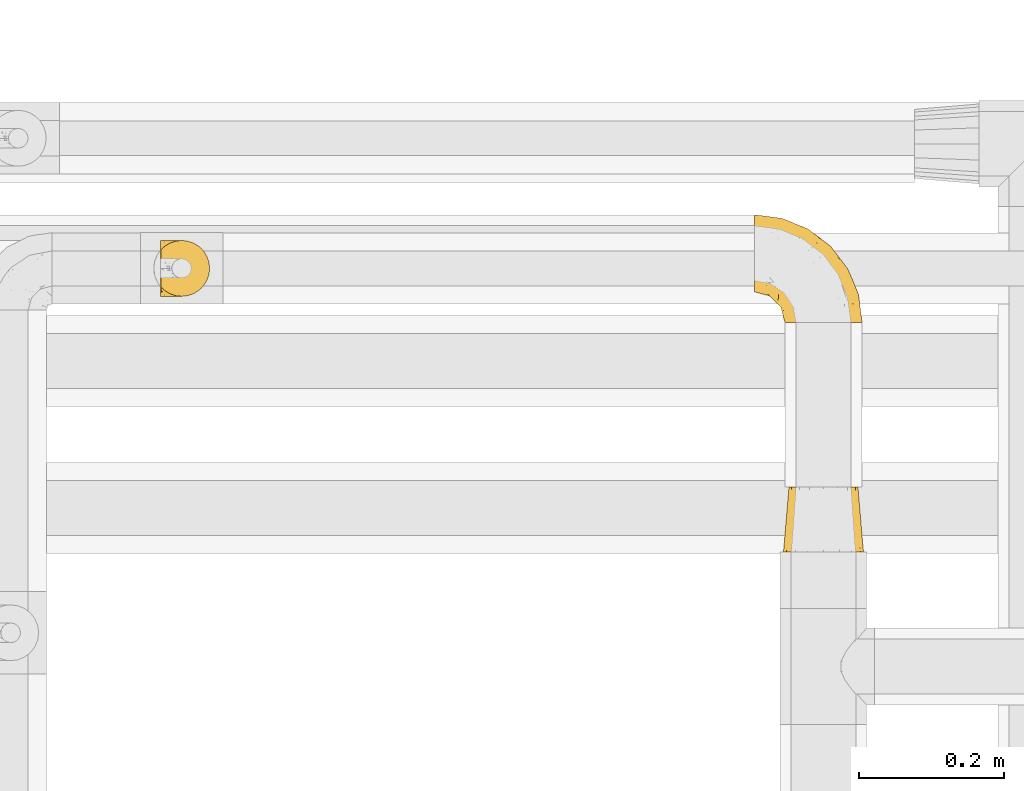
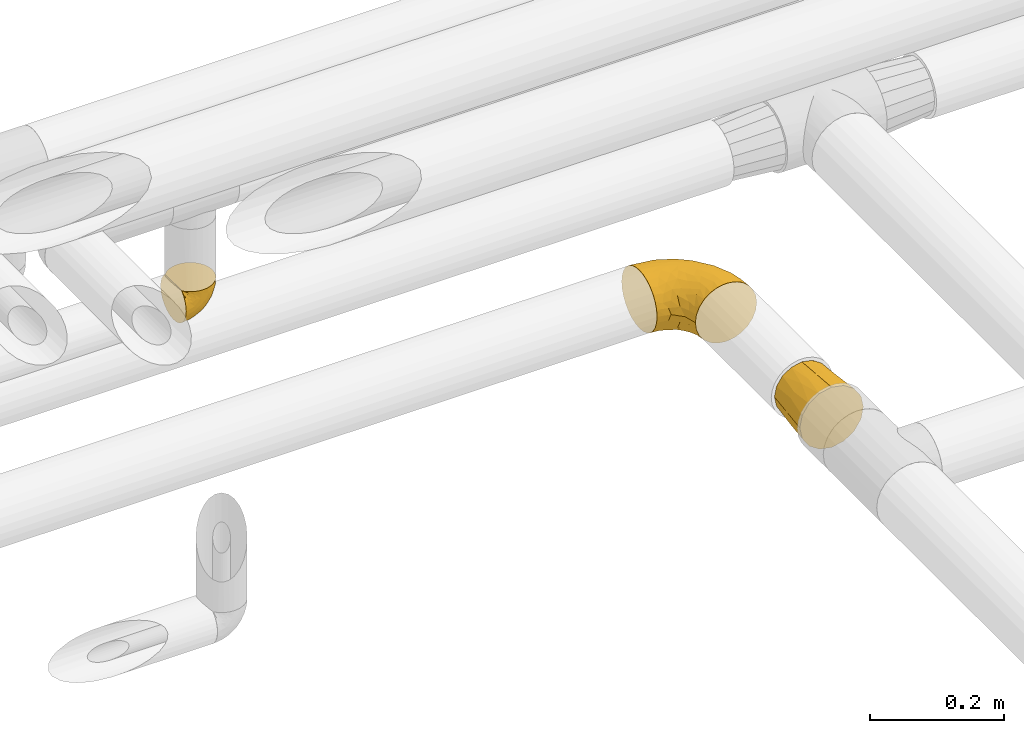
# One storey, part 366 of 827: 3 coverings.
"""IFC2X3 building model written with IfcOpenShell, lengths in millimetres."""

from ifc_helpers import new_model, entity, si_unit, converted_unit, derived_unit, direction, frame, origin, place, context, subcontext, project, spatial, faceted_brep, element, save


model = new_model("IFC2X3")

# Units and contexts
model_context = context("Model", 3, precision=0.01, world=origin(), true_north=direction((6.12303176911189e-17, 1.0)))
body_context = subcontext(model_context, "Body", "Model", "MODEL_VIEW")
ifc_project = project(units=[si_unit("LENGTHUNIT", "METRE", prefix="MILLI"), si_unit("AREAUNIT", "SQUARE_METRE"), si_unit("VOLUMEUNIT", "CUBIC_METRE"), converted_unit("PLANEANGLEUNIT", "DEGREE", entity("IfcRatioMeasure", 0.0174532925199433), si_unit("PLANEANGLEUNIT", "RADIAN"), dimensions=[0, 0, 0, 0, 0, 0, 0]), si_unit("MASSUNIT", "GRAM", prefix="KILO"), derived_unit("MASSDENSITYUNIT", [(si_unit("MASSUNIT", "GRAM", prefix="KILO"), 1), (si_unit("LENGTHUNIT", "METRE"), -3)]), derived_unit("MOMENTOFINERTIAUNIT", [(si_unit("LENGTHUNIT", "METRE"), 4)]), si_unit("TIMEUNIT", "SECOND"), si_unit("FREQUENCYUNIT", "HERTZ"), si_unit("THERMODYNAMICTEMPERATUREUNIT", "DEGREE_CELSIUS"), derived_unit("THERMALTRANSMITTANCEUNIT", [(si_unit("MASSUNIT", "GRAM", prefix="KILO"), 1), (si_unit("THERMODYNAMICTEMPERATUREUNIT", "KELVIN"), -1), (si_unit("TIMEUNIT", "SECOND"), -3)]), derived_unit("VOLUMETRICFLOWRATEUNIT", [(si_unit("LENGTHUNIT", "METRE"), 3), (si_unit("TIMEUNIT", "SECOND"), -1)]), derived_unit("MASSFLOWRATEUNIT", [(si_unit("MASSUNIT", "GRAM", prefix="KILO"), 1), (si_unit("TIMEUNIT", "SECOND"), -1)]), derived_unit("ROTATIONALFREQUENCYUNIT", [(si_unit("TIMEUNIT", "SECOND"), -1)]), si_unit("ELECTRICCURRENTUNIT", "AMPERE"), si_unit("ELECTRICVOLTAGEUNIT", "VOLT"), si_unit("POWERUNIT", "WATT"), si_unit("FORCEUNIT", "NEWTON", prefix="KILO"), si_unit("ILLUMINANCEUNIT", "LUX"), si_unit("LUMINOUSFLUXUNIT", "LUMEN"), si_unit("LUMINOUSINTENSITYUNIT", "CANDELA"), derived_unit("USERDEFINED", [(si_unit("MASSUNIT", "GRAM", prefix="KILO"), -1), (si_unit("LENGTHUNIT", "METRE"), -2), (si_unit("TIMEUNIT", "SECOND"), 3), (si_unit("LUMINOUSFLUXUNIT", "LUMEN"), 1)]), derived_unit("LINEARVELOCITYUNIT", [(si_unit("LENGTHUNIT", "METRE"), 1), (si_unit("TIMEUNIT", "SECOND"), -1)]), si_unit("PRESSUREUNIT", "PASCAL"), derived_unit("USERDEFINED", [(si_unit("LENGTHUNIT", "METRE"), -2), (si_unit("MASSUNIT", "GRAM", prefix="KILO"), 1), (si_unit("TIMEUNIT", "SECOND"), -2)]), derived_unit("LINEARFORCEUNIT", [(si_unit("MASSUNIT", "GRAM", prefix="KILO"), 1), (si_unit("LENGTHUNIT", "METRE"), 1), (si_unit("TIMEUNIT", "SECOND"), -2), (si_unit("LENGTHUNIT", "METRE"), -1)]), derived_unit("PLANARFORCEUNIT", [(si_unit("MASSUNIT", "GRAM", prefix="KILO"), 1), (si_unit("LENGTHUNIT", "METRE"), 1), (si_unit("TIMEUNIT", "SECOND"), -2), (si_unit("LENGTHUNIT", "METRE"), -2)])], contexts=[model_context])

# Site, building, storey
site_placement = place(None, origin())
site = spatial("IfcSite", under=ifc_project, at=site_placement, CompositionType="ELEMENT")
building_placement = place(site_placement, origin())
building = spatial("IfcBuilding", under=site, at=building_placement, CompositionType="ELEMENT")
storey_placement = place(building_placement, frame((0.0, 0.0, 28200.0)))
storey = spatial("IfcBuildingStorey", under=building, at=storey_placement, Name="08", CompositionType="ELEMENT", Elevation=28200.0)

# Coverings
covering_1_placement = place(storey_placement, frame((36834.33, 18896.36, 3159.95)))
element("IfcCovering", 1, at=covering_1_placement, inside=storey, Name=":ADSK_", ObjectType=":ADSK_", PredefinedType="INSULATION", context=body_context, shape_type="Brep", body=[
    faceted_brep([(47.38, 5.41, 69.15), (54.67, 9.99, 69.15), (60.76, 16.08, 69.15), (65.34, 23.37, 69.15), (68.18, 31.49, 69.15), (69.15, 40.05, 69.15), (68.18, 48.61, 69.15), (65.33, 56.73, 69.15), (60.75, 64.02, 69.15), (54.66, 70.11, 69.15), (47.37, 74.69, 69.15), (39.25, 77.53, 69.15), (30.7, 78.5, 69.15), (22.59, 77.63, 69.15), (14.86, 75.08, 69.15), (7.84, 70.97, 69.15), (1.85, 65.47, 69.15), (1.85, 63.27, 69.15), (1.85, 61.53, 69.15), (1.85, 59.57, 69.15), (1.85, 57.6, 69.15), (1.85, 55.63, 69.15), (1.85, 53.67, 69.15), (1.85, 51.7, 69.15), (1.85, 49.73, 69.15), (1.85, 47.54, 69.15), (1.85, 45.34, 69.15), (1.85, 43.15, 69.15), (1.85, 40.96, 69.15), (1.85, 38.76, 69.15), (1.85, 36.57, 69.15), (1.85, 34.37, 69.15), (1.85, 32.18, 69.15), (1.85, 29.98, 69.15), (1.85, 27.79, 69.15), (1.85, 25.6, 69.15), (1.85, 23.4, 69.15), (1.85, 21.21, 69.15), (1.85, 19.01, 69.15), (1.85, 16.82, 69.15), (1.85, 14.62, 69.15), (7.85, 9.12, 69.15), (14.88, 5.0, 69.15), (22.61, 2.46, 69.15), (30.7, 1.6, 69.15), (39.26, 2.56, 69.15), (1.6, 65.47, 68.89), (1.6, 70.97, 62.89), (1.6, 75.09, 55.87), (1.6, 77.63, 48.14), (1.6, 78.5, 40.05), (1.6, 77.19, 30.09), (1.6, 73.34, 20.82), (1.6, 67.23, 12.86), (1.6, 59.27, 6.75), (1.6, 50.0, 2.91), (1.6, 40.05, 1.6), (1.6, 30.09, 2.91), (1.6, 20.82, 6.75), (1.6, 12.86, 12.86), (1.6, 6.75, 20.82), (1.6, 2.91, 30.09), (1.6, 1.6, 40.05), (1.6, 2.46, 48.14), (1.6, 5.0, 55.87), (1.6, 9.12, 62.89), (1.6, 14.62, 68.89), (1.6, 16.82, 68.89), (1.6, 17.8, 68.89), (1.6, 19.39, 68.89), (1.6, 20.98, 68.89), (1.6, 22.57, 68.89), (1.6, 24.16, 68.89), (1.6, 25.75, 68.89), (1.6, 27.33, 68.89), (1.6, 28.92, 68.89), (1.6, 30.51, 68.89), (1.6, 32.1, 68.89), (1.6, 33.69, 68.89), (1.6, 35.28, 68.89), (1.6, 36.87, 68.89), (1.6, 38.46, 68.89), (1.6, 40.05, 68.89), (1.6, 41.63, 68.89), (1.6, 43.22, 68.89), (1.6, 44.81, 68.89), (1.6, 46.4, 68.89), (1.6, 47.99, 68.89), (1.6, 49.58, 68.89), (1.6, 51.17, 68.89), (1.6, 52.76, 68.89), (1.6, 54.72, 68.89), (1.6, 56.69, 68.89), (1.6, 58.88, 68.89), (1.6, 61.08, 68.89), (1.6, 63.27, 68.89), (1.78, 37.77, 68.97), (1.77, 36.07, 68.96), (1.78, 32.96, 68.97), (1.77, 31.36, 68.97), (1.79, 56.52, 68.98), (1.78, 54.96, 68.97), (1.76, 18.75, 68.96), (1.77, 58.07, 68.96), (1.77, 50.37, 68.96), (1.76, 23.36, 68.96), (1.77, 24.95, 68.96), (1.77, 42.43, 68.96), (1.8, 15.97, 69.0), (1.76, 51.96, 68.96), (1.77, 53.47, 68.96), (1.78, 48.63, 68.97), (1.77, 63.93, 68.96), (1.77, 40.93, 68.96), (1.76, 29.72, 68.96), (1.77, 62.4, 68.97), (1.78, 60.92, 68.97), (1.77, 17.31, 68.97), (1.77, 21.74, 68.96), (1.77, 34.56, 68.96), (1.78, 20.18, 68.97), (1.77, 14.62, 68.97), (1.8, 14.62, 69.02), (1.82, 14.62, 69.08), (1.77, 65.47, 68.97), (1.72, 65.47, 68.94), (1.66, 65.47, 68.92), (1.76, 59.5, 68.96), (1.77, 47.1, 68.96), (1.76, 45.61, 68.95), (1.77, 28.18, 68.96), (1.66, 14.62, 68.92), (1.72, 14.62, 68.94), (1.78, 26.61, 68.98), (1.82, 65.47, 69.08), (1.8, 65.47, 69.02), (1.77, 39.32, 68.96), (1.78, 44.12, 68.97), (3.72, 72.26, 61.33), (7.41, 76.57, 53.1), (6.13, 71.77, 63.33), (21.47, 78.5, 49.27), (19.34, 77.9, 55.53), (26.8, 78.5, 54.6), (8.87, 78.5, 41.99), (9.2, 75.52, 57.07), (12.79, 76.13, 57.95), (14.62, 77.81, 51.56), (7.34, 78.5, 41.58), (5.33, 72.4, 61.7), (17.64, 76.56, 63.33), (7.7, 71.77, 65.0), (9.41, 72.25, 67.02), (28.75, 78.5, 61.87), (16.15, 78.5, 43.94), (14.14, 75.75, 61.21), (29.16, 78.5, 63.4), (57.02, 50.46, 33.11), (64.92, 52.75, 52.82), (64.0, 40.05, 43.3), (11.92, 77.7, 33.73), (19.16, 77.66, 36.52), (28.65, 71.02, 24.87), (24.62, 63.45, 14.17), (15.19, 70.55, 18.43), (18.36, 75.57, 28.67), (9.2, 75.57, 26.0), (46.98, 72.61, 49.25), (50.24, 72.61, 59.72), (56.1, 67.24, 55.1), (28.97, 77.74, 44.72), (54.46, 57.43, 34.15), (21.34, 47.19, 5.25), (18.4, 54.76, 6.75), (66.44, 40.05, 55.54), (12.07, 63.45, 10.47), (45.49, 60.1, 25.49), (50.57, 63.72, 35.53), (36.04, 76.83, 48.22), (42.07, 76.34, 58.71), (62.12, 60.51, 57.42), (37.37, 72.59, 34.84), (29.39, 76.05, 36.87), (53.59, 66.15, 45.01), (58.06, 60.51, 44.4), (49.27, 51.88, 23.96), (29.63, 55.34, 11.2), (33.21, 48.67, 10.56), (40.1, 53.89, 16.81), (44.08, 46.73, 17.38), (49.36, 40.05, 21.38), (56.68, 40.05, 32.34), (15.2, 40.05, 4.3), (35.57, 63.95, 20.65), (41.7, 67.24, 29.66), (46.4, 69.62, 39.6), (41.41, 73.6, 42.55), (27.45, 40.05, 6.74), (38.4, 40.05, 14.06), (12.99, 4.52, 26.84), (21.33, 32.72, 5.28), (42.89, 27.18, 18.52), (57.04, 29.63, 33.13), (56.11, 12.86, 55.1), (62.13, 19.59, 57.43), (21.89, 9.54, 20.72), (16.62, 16.64, 11.46), (32.9, 17.48, 17.69), (46.99, 7.49, 49.26), (50.25, 7.49, 59.73), (42.08, 3.75, 58.71), (49.91, 20.75, 29.72), (15.6, 2.33, 35.35), (16.15, 1.6, 43.94), (8.87, 1.6, 41.99), (29.16, 1.6, 63.4), (13.16, 26.94, 4.93), (10.83, 9.54, 17.46), (33.8, 31.21, 10.94), (25.02, 25.33, 8.92), (64.92, 27.35, 52.83), (32.83, 8.17, 29.34), (20.56, 4.3, 30.26), (58.07, 19.59, 44.4), (21.46, 2.23, 39.06), (28.1, 2.45, 43.06), (26.8, 1.6, 54.6), (21.47, 1.6, 49.27), (51.29, 12.86, 42.69), (36.04, 3.27, 48.2), (28.75, 1.6, 61.87), (8.45, 2.29, 33.44), (41.73, 12.86, 29.67), (39.27, 6.89, 38.5), (33.56, 12.43, 23.35), (27.29, 4.1, 34.97), (7.41, 3.53, 53.1), (3.51, 6.88, 59.68), (4.68, 8.16, 62.19), (5.52, 9.02, 64.11), (8.75, 5.0, 57.97), (12.79, 3.96, 57.95), (17.65, 3.52, 63.33), (13.9, 2.4, 51.77), (9.42, 7.83, 67.02), (7.68, 8.32, 64.98), (19.33, 2.19, 55.53), (14.13, 4.34, 61.22)], [[[0, 1, 2, 3, 4, 5, 6, 7, 8, 9, 10, 11, 12, 13, 14, 15, 16, 17, 18, 19, 20, 21, 22, 23, 24, 25, 26, 27, 28, 29, 30, 31, 32, 33, 34, 35, 36, 37, 38, 39, 40, 41, 42, 43, 44, 45]], [[46, 47, 48, 49, 50, 51, 52, 53, 54, 55, 56, 57, 58, 59, 60, 61, 62, 63, 64, 65, 66, 67, 68, 69, 70, 71, 72, 73, 74, 75, 76, 77, 78, 79, 80, 81, 82, 83, 84, 85, 86, 87, 88, 89, 90, 91, 92, 93, 94, 95]], [[96, 97, 30]], [[98, 77, 99]], [[100, 101, 21]], [[69, 68, 102]], [[20, 19, 103]], [[24, 23, 104]], [[20, 103, 100]], [[72, 105, 106]], [[84, 83, 107]], [[89, 88, 104]], [[108, 67, 66]], [[109, 110, 90]], [[111, 25, 24]], [[112, 17, 16]], [[82, 113, 83]], [[109, 23, 22]], [[114, 76, 75]], [[105, 36, 106]], [[104, 111, 24]], [[18, 115, 116]], [[97, 96, 80]], [[67, 108, 117]], [[105, 71, 118]], [[31, 97, 119]], [[102, 120, 69]], [[108, 121, 122, 123, 40]], [[112, 95, 115]], [[17, 115, 18]], [[94, 116, 115]], [[117, 68, 67]], [[38, 117, 39]], [[112, 124, 125, 126, 46]], [[17, 112, 115]], [[70, 120, 118]], [[39, 117, 108]], [[120, 38, 37]], [[120, 37, 118]], [[120, 70, 69]], [[116, 94, 127]], [[128, 86, 129]], [[117, 38, 102]], [[74, 130, 75]], [[99, 33, 32]], [[115, 95, 94]], [[39, 108, 40]], [[108, 66, 131, 132, 121]], [[105, 72, 71]], [[118, 37, 36]], [[71, 70, 118]], [[35, 106, 36]], [[36, 105, 118]], [[35, 133, 106]], [[74, 73, 133]], [[106, 133, 73]], [[99, 114, 33]], [[133, 35, 34]], [[73, 72, 106]], [[95, 112, 46]], [[112, 16, 134, 135, 124]], [[130, 114, 75]], [[99, 76, 114]], [[114, 130, 33]], [[34, 33, 130]], [[78, 77, 98]], [[98, 119, 78]], [[130, 133, 34]], [[133, 130, 74]], [[79, 97, 80]], [[98, 99, 32]], [[98, 32, 31]], [[77, 76, 99]], [[97, 79, 119]], [[136, 96, 29]], [[30, 97, 31]], [[136, 29, 28]], [[81, 80, 96]], [[29, 96, 30]], [[31, 119, 98]], [[119, 79, 78]], [[96, 136, 81]], [[82, 81, 136]], [[113, 107, 83]], [[84, 107, 137]], [[107, 27, 137]], [[113, 28, 107]], [[27, 107, 28]], [[85, 84, 137]], [[137, 27, 26]], [[113, 136, 28]], [[136, 113, 82]], [[109, 89, 104]], [[86, 85, 129]], [[89, 109, 90]], [[111, 87, 128]], [[26, 129, 137]], [[88, 111, 104]], [[25, 111, 128]], [[22, 110, 109]], [[23, 109, 104]], [[110, 91, 90]], [[100, 92, 101]], [[110, 22, 101]], [[91, 110, 101]], [[116, 19, 18]], [[111, 88, 87]], [[127, 103, 19]], [[25, 128, 26]], [[86, 128, 87]], [[128, 129, 26]], [[137, 129, 85]], [[120, 102, 38]], [[117, 102, 68]], [[91, 101, 92]], [[21, 101, 22]], [[93, 92, 103]], [[100, 21, 20]], [[100, 103, 92]], [[127, 93, 103]], [[93, 127, 94]], [[116, 127, 19]], [[126, 138, 47]], [[48, 138, 139]], [[140, 125, 124]], [[141, 142, 143]], [[144, 49, 139]], [[145, 140, 146]], [[48, 139, 49]], [[139, 145, 147]], [[49, 144, 148, 50]], [[126, 125, 149]], [[14, 13, 150]], [[151, 146, 140]], [[149, 140, 145]], [[152, 151, 135]], [[152, 14, 150]], [[16, 15, 134]], [[13, 153, 150]], [[124, 151, 140]], [[141, 147, 142]], [[14, 152, 15]], [[15, 152, 134]], [[47, 46, 126]], [[139, 154, 144]], [[138, 48, 47]], [[125, 140, 149]], [[135, 134, 152]], [[146, 155, 142]], [[145, 146, 147]], [[149, 139, 138]], [[147, 141, 154]], [[147, 146, 142]], [[139, 147, 154]], [[139, 149, 145]], [[149, 138, 126]], [[155, 146, 151]], [[150, 143, 142]], [[152, 155, 151]], [[150, 142, 155]], [[13, 12, 156, 153]], [[153, 143, 150]], [[152, 150, 155]], [[151, 124, 135]], [[157, 158, 159]], [[160, 154, 161]], [[162, 163, 164]], [[165, 166, 160]], [[167, 168, 169]], [[141, 170, 161]], [[156, 12, 11]], [[158, 157, 171]], [[172, 55, 173]], [[158, 6, 174]], [[175, 54, 53]], [[52, 166, 164]], [[52, 164, 53]], [[54, 175, 173]], [[166, 52, 51]], [[176, 177, 171]], [[178, 143, 179]], [[156, 11, 179]], [[8, 7, 180]], [[169, 9, 8]], [[179, 143, 153, 156]], [[179, 11, 10]], [[168, 179, 10]], [[181, 162, 182]], [[179, 167, 178]], [[183, 184, 177]], [[183, 169, 184]], [[176, 171, 185]], [[172, 186, 187]], [[158, 7, 6]], [[159, 158, 174]], [[184, 180, 158]], [[54, 173, 55]], [[180, 169, 8]], [[188, 189, 187]], [[9, 168, 10]], [[186, 188, 187]], [[190, 157, 159, 191]], [[55, 172, 192]], [[176, 193, 194]], [[161, 170, 182]], [[162, 164, 165]], [[175, 164, 163]], [[51, 50, 148]], [[167, 195, 196]], [[178, 182, 170]], [[6, 5, 174]], [[158, 180, 7]], [[169, 180, 184]], [[169, 168, 9]], [[179, 168, 167]], [[182, 162, 165]], [[162, 194, 193]], [[161, 165, 160]], [[195, 181, 196]], [[192, 172, 197]], [[192, 56, 55]], [[189, 190, 198]], [[198, 197, 187]], [[172, 187, 197]], [[185, 189, 188]], [[198, 187, 189]], [[186, 172, 173]], [[173, 163, 186]], [[193, 186, 163]], [[176, 185, 188]], [[185, 157, 190]], [[188, 186, 193]], [[177, 176, 194]], [[188, 193, 176]], [[162, 193, 163]], [[195, 177, 194]], [[171, 177, 184]], [[181, 195, 194]], [[183, 167, 169]], [[162, 181, 194]], [[196, 182, 178]], [[158, 171, 184]], [[171, 157, 185]], [[177, 195, 183]], [[167, 183, 195]], [[182, 196, 181]], [[178, 170, 143]], [[178, 167, 196]], [[164, 175, 53]], [[173, 175, 163]], [[160, 51, 148]], [[164, 166, 165]], [[51, 160, 166]], [[160, 148, 144, 154]], [[141, 161, 154]], [[182, 165, 161]], [[190, 189, 185]], [[143, 170, 141]], [[60, 199, 61]], [[197, 200, 192]], [[201, 190, 202]], [[200, 57, 192]], [[203, 204, 2]], [[205, 206, 207]], [[208, 209, 210]], [[211, 207, 201]], [[212, 213, 214]], [[45, 215, 210]], [[216, 206, 58]], [[45, 44, 215]], [[59, 217, 60]], [[60, 217, 199]], [[0, 45, 210]], [[218, 201, 219]], [[202, 159, 220]], [[205, 221, 222]], [[223, 204, 203]], [[1, 203, 2]], [[57, 200, 216]], [[220, 3, 204]], [[220, 174, 4]], [[1, 0, 209]], [[212, 224, 213]], [[225, 226, 227]], [[228, 223, 203]], [[208, 210, 229]], [[210, 226, 229]], [[3, 220, 4]], [[58, 206, 59]], [[209, 203, 1]], [[202, 220, 223]], [[228, 203, 208]], [[202, 211, 201]], [[3, 2, 204]], [[202, 190, 191, 159]], [[210, 215, 230, 226]], [[199, 212, 231]], [[232, 233, 221]], [[233, 208, 229]], [[207, 206, 219]], [[217, 206, 205]], [[227, 224, 225]], [[233, 232, 228]], [[201, 207, 219]], [[234, 232, 221]], [[218, 219, 200]], [[202, 223, 211]], [[174, 220, 159]], [[174, 5, 4]], [[61, 231, 62]], [[220, 204, 223]], [[210, 209, 0]], [[203, 209, 208]], [[225, 233, 229]], [[224, 227, 213]], [[221, 233, 235]], [[57, 56, 192]], [[198, 218, 197]], [[200, 219, 216]], [[201, 198, 190]], [[197, 218, 200]], [[198, 201, 218]], [[206, 216, 219]], [[58, 57, 216]], [[231, 212, 214]], [[222, 212, 199]], [[228, 211, 223]], [[207, 211, 232]], [[62, 231, 214]], [[199, 231, 61]], [[233, 228, 208]], [[211, 228, 232]], [[222, 221, 235]], [[234, 205, 207]], [[206, 217, 59]], [[199, 217, 205]], [[205, 222, 199]], [[224, 222, 235]], [[222, 224, 212]], [[224, 235, 225]], [[233, 225, 235]], [[226, 225, 229]], [[205, 234, 221]], [[207, 232, 234]], [[63, 214, 236]], [[214, 213, 236]], [[214, 63, 62]], [[237, 236, 238]], [[238, 132, 131]], [[236, 237, 64]], [[239, 240, 241]], [[63, 236, 64]], [[131, 66, 65]], [[237, 131, 65]], [[242, 230, 43]], [[237, 65, 64]], [[239, 121, 132]], [[42, 242, 43]], [[241, 240, 243]], [[41, 123, 244]], [[43, 230, 215, 44]], [[244, 122, 245]], [[227, 246, 243]], [[241, 247, 245]], [[121, 239, 245]], [[41, 40, 123]], [[132, 238, 239]], [[244, 42, 41]], [[131, 237, 238]], [[240, 239, 238]], [[245, 239, 241]], [[247, 241, 246]], [[247, 244, 245]], [[238, 236, 240]], [[243, 236, 213]], [[236, 243, 240]], [[227, 226, 246]], [[243, 213, 227]], [[242, 246, 226]], [[243, 246, 241]], [[246, 242, 247]], [[244, 247, 242]], [[242, 226, 230]], [[42, 244, 242]], [[122, 244, 123]], [[122, 121, 245]]]),
])
covering_2_placement = place(storey_placement, frame((37651.7, 18860.64, 2845.44)))
element("IfcCovering", 2, at=covering_2_placement, inside=storey, Name=":ADSK_", ObjectType=":ADSK_", PredefinedType="INSULATION", context=body_context, shape_type="Brep", body=[
    faceted_brep([(1.6, 148.32, 66.44), (1.6, 149.65, 54.64), (1.6, 148.32, 42.83), (1.6, 144.39, 31.62), (1.6, 138.07, 21.56), (1.6, 129.66, 13.16), (1.6, 119.6, 6.84), (1.6, 108.39, 2.92), (1.6, 96.6, 1.6), (1.6, 84.79, 2.93), (1.6, 73.57, 6.85), (1.6, 63.51, 13.18), (1.6, 55.11, 21.58), (1.6, 48.79, 31.64), (1.6, 44.87, 42.85), (1.6, 43.55, 54.65), (1.6, 44.88, 66.46), (1.6, 48.8, 77.67), (1.6, 55.13, 87.73), (1.6, 63.53, 96.13), (1.6, 73.59, 102.45), (1.6, 84.8, 106.37), (1.6, 96.6, 107.7), (1.6, 108.41, 106.36), (1.6, 119.62, 102.44), (1.6, 129.68, 96.11), (1.6, 138.08, 87.71), (1.6, 144.4, 77.65), (45.35, 1.6, 40.92), (50.65, 1.6, 28.12), (59.08, 1.6, 17.14), (70.07, 1.6, 8.71), (82.86, 1.6, 3.41), (96.6, 1.6, 1.6), (110.33, 1.6, 3.41), (123.12, 1.6, 8.71), (134.11, 1.6, 17.14), (142.54, 1.6, 28.12), (147.84, 1.6, 40.92), (149.65, 1.6, 54.65), (147.84, 1.6, 68.38), (142.54, 1.6, 81.17), (134.11, 1.6, 92.16), (123.12, 1.6, 100.59), (110.33, 1.6, 105.89), (96.6, 1.6, 107.7), (82.86, 1.6, 105.89), (70.07, 1.6, 100.59), (59.08, 1.6, 92.16), (50.65, 1.6, 81.17), (45.35, 1.6, 68.38), (43.55, 1.6, 54.65), (137.19, 27.97, 85.53), (141.79, 37.1, 73.42), (128.89, 58.27, 83.78), (146.54, 27.13, 64.23), (144.6, 39.91, 54.65), (69.77, 109.11, 96.72), (94.41, 94.42, 93.36), (87.22, 110.94, 84.47), (117.2, 89.69, 71.37), (129.81, 75.62, 54.65), (106.28, 106.28, 54.65), (101.45, 60.12, 103.48), (115.81, 41.42, 100.91), (109.14, 63.22, 99.1), (107.65, 32.05, 105.43), (93.36, 52.13, 106.79), (59.44, 123.27, 89.81), (63.23, 129.33, 79.59), (35.59, 138.3, 81.29), (132.3, 62.96, 74.01), (138.41, 55.89, 64.14), (126.28, 37.4, 94.75), (39.91, 144.6, 54.64), (37.44, 142.66, 70.74), (90.35, 117.85, 68.3), (65.0, 134.01, 66.04), (85.4, 89.25, 100.73), (26.66, 103.34, 106.78), (29.88, 113.52, 103.6), (78.45, 57.44, 107.7), (85.2, 44.2, 107.7), (91.95, 30.95, 107.7), (77.98, 77.99, 106.07), (29.55, 132.66, 90.59), (41.42, 121.53, 97.43), (111.13, 86.93, 84.51), (114.67, 68.4, 93.3), (57.43, 78.45, 107.7), (67.94, 67.95, 107.7), (14.64, 94.53, 107.7), (30.95, 91.95, 107.7), (52.13, 93.36, 106.79), (44.19, 85.2, 107.7), (60.12, 101.45, 103.47), (75.62, 129.81, 54.64), (94.27, 16.28, 107.7), (24.59, 42.46, 76.99), (34.69, 40.4, 84.28), (31.15, 49.71, 91.11), (75.18, 39.41, 106.26), (67.55, 31.27, 102.6), (79.36, 27.7, 106.09), (84.32, 16.71, 106.56), (40.81, 70.68, 105.36), (29.93, 81.7, 106.74), (70.24, 16.68, 101.59), (37.93, 22.57, 54.65), (40.15, 14.26, 54.65), (42.1, 17.68, 67.71), (55.38, 19.59, 91.36), (52.17, 33.49, 94.33), (44.32, 33.02, 87.1), (19.85, 40.69, 65.84), (14.26, 40.15, 54.65), (22.57, 37.93, 54.65), (34.17, 31.04, 68.93), (54.85, 45.29, 100.82), (44.63, 23.55, 79.84), (47.52, 11.36, 77.13), (59.1, 59.11, 105.9), (44.11, 57.43, 101.53), (53.21, 68.97, 106.72), (62.86, 20.38, 97.75), (20.58, 72.47, 103.08), (15.79, 83.67, 106.39), (27.67, 60.67, 98.1), (13.49, 61.01, 95.02), (18.04, 51.85, 86.9), (12.44, 46.07, 74.42), (30.25, 30.25, 54.65), (66.71, 46.66, 105.28), (42.52, 43.01, 92.88), (55.38, 19.58, 17.93), (20.57, 72.44, 6.22), (42.11, 17.67, 41.58), (57.43, 78.45, 1.6), (53.22, 68.97, 2.57), (40.81, 70.65, 3.94), (19.85, 40.69, 43.46), (24.58, 42.45, 32.32), (34.16, 31.04, 40.38), (42.5, 42.99, 16.44), (54.93, 45.18, 8.47), (52.13, 33.46, 15.01), (27.66, 60.64, 11.21), (44.12, 57.37, 7.78), (78.45, 57.43, 1.6), (85.2, 44.19, 1.6), (75.17, 39.35, 3.04), (94.27, 16.27, 1.6), (84.32, 16.7, 2.73), (30.95, 91.95, 1.6), (44.19, 85.2, 1.6), (29.98, 81.68, 2.55), (66.78, 46.68, 3.99), (67.55, 31.26, 6.69), (70.24, 16.68, 7.71), (79.36, 27.7, 3.21), (13.48, 60.99, 14.29), (18.03, 51.84, 22.42), (34.66, 40.41, 25.03), (31.14, 49.72, 18.18), (12.43, 46.06, 34.89), (14.64, 94.53, 1.6), (47.52, 11.35, 32.17), (44.28, 33.02, 22.23), (15.8, 83.65, 2.91), (62.86, 20.38, 11.54), (67.94, 67.94, 1.6), (59.12, 59.12, 3.38), (44.64, 23.53, 29.46), (91.95, 30.95, 1.6), (128.89, 58.27, 25.52), (137.19, 27.97, 23.76), (126.28, 37.4, 14.54), (115.81, 41.41, 8.38), (146.53, 27.21, 45.07), (141.79, 37.09, 35.87), (139.45, 53.2, 45.14), (93.36, 52.13, 2.5), (26.67, 103.34, 2.51), (29.87, 113.5, 5.68), (60.12, 101.45, 5.82), (94.41, 94.41, 15.93), (69.76, 109.08, 12.54), (87.19, 110.95, 24.81), (52.13, 93.36, 2.5), (77.98, 77.98, 3.22), (107.65, 32.05, 3.86), (131.74, 64.63, 35.85), (59.44, 123.25, 19.46), (29.54, 132.65, 18.68), (63.2, 129.32, 29.68), (27.9, 139.96, 27.95), (90.35, 117.85, 40.99), (117.2, 89.69, 37.92), (41.39, 121.51, 11.85), (109.14, 63.23, 10.19), (85.46, 89.17, 8.55), (37.43, 142.66, 38.53), (114.67, 68.4, 16.0), (111.12, 86.94, 24.79), (101.45, 60.12, 5.82), (65.16, 133.2, 40.56)], [[[0, 1, 2, 3, 4, 5, 6, 7, 8, 9, 10, 11, 12, 13, 14, 15, 16, 17, 18, 19, 20, 21, 22, 23, 24, 25, 26, 27]], [[28, 29, 30, 31, 32, 33, 34, 35, 36, 37, 38, 39, 40, 41, 42, 43, 44, 45, 46, 47, 48, 49, 50, 51]], [[52, 53, 54]], [[55, 39, 56]], [[57, 58, 59]], [[60, 61, 62]], [[63, 64, 65]], [[66, 63, 67]], [[68, 69, 70]], [[53, 71, 54]], [[41, 40, 53]], [[53, 72, 71]], [[73, 42, 52]], [[42, 41, 52]], [[74, 0, 75]], [[69, 76, 77]], [[43, 73, 64]], [[45, 44, 66]], [[57, 78, 58]], [[23, 79, 80]], [[67, 81, 82, 83]], [[67, 84, 81]], [[24, 23, 80]], [[25, 85, 26]], [[86, 85, 25]], [[42, 73, 43]], [[0, 27, 75]], [[25, 24, 86]], [[70, 26, 85]], [[0, 74, 1]], [[68, 85, 86]], [[66, 64, 63]], [[60, 59, 87]], [[54, 87, 88]], [[76, 60, 62]], [[84, 89, 90, 81]], [[79, 22, 91, 92]], [[77, 74, 75]], [[93, 92, 94, 89]], [[80, 86, 24]], [[40, 55, 53]], [[76, 59, 60]], [[93, 84, 95]], [[76, 62, 96]], [[55, 72, 53]], [[70, 27, 26]], [[75, 70, 69]], [[78, 84, 63]], [[93, 79, 92]], [[95, 86, 80]], [[77, 76, 96]], [[59, 69, 68]], [[57, 68, 86]], [[68, 57, 59]], [[59, 58, 87]], [[76, 69, 59]], [[88, 87, 58]], [[87, 54, 71]], [[86, 95, 57]], [[78, 57, 95]], [[84, 78, 95]], [[78, 63, 65]], [[58, 78, 65]], [[54, 88, 73]], [[84, 93, 89]], [[79, 95, 80]], [[79, 93, 95]], [[22, 79, 23]], [[66, 83, 97, 45]], [[84, 67, 63]], [[83, 66, 67]], [[64, 44, 43]], [[64, 66, 44]], [[65, 73, 88]], [[53, 52, 41]], [[73, 52, 54]], [[73, 65, 64]], [[65, 88, 58]], [[39, 55, 40]], [[72, 55, 56]], [[56, 61, 72]], [[60, 72, 61]], [[72, 60, 71]], [[87, 71, 60]], [[27, 70, 75]], [[68, 70, 85]], [[74, 77, 96]], [[69, 77, 75]], [[98, 99, 100]], [[46, 45, 97]], [[101, 102, 103]], [[103, 104, 83]], [[105, 94, 106]], [[107, 103, 102]], [[108, 109, 51, 110]], [[111, 112, 113]], [[114, 115, 116]], [[47, 104, 107]], [[110, 117, 108]], [[49, 48, 111]], [[102, 118, 112]], [[119, 120, 111]], [[50, 49, 120]], [[121, 122, 118]], [[105, 123, 89]], [[124, 48, 107]], [[20, 19, 125]], [[121, 81, 90]], [[117, 119, 99]], [[21, 20, 126]], [[22, 21, 91]], [[105, 125, 127]], [[110, 51, 50]], [[19, 128, 125]], [[16, 15, 115]], [[129, 98, 100]], [[126, 91, 21]], [[128, 129, 127]], [[122, 123, 105]], [[114, 117, 98]], [[17, 16, 130]], [[18, 128, 19]], [[129, 18, 17]], [[125, 106, 126]], [[115, 114, 16]], [[130, 129, 17]], [[114, 98, 130]], [[117, 116, 131, 108]], [[99, 119, 113]], [[122, 121, 123]], [[92, 126, 106]], [[105, 127, 122]], [[132, 121, 118]], [[114, 130, 16]], [[129, 130, 98]], [[50, 120, 110]], [[129, 128, 18]], [[125, 128, 127]], [[125, 126, 20]], [[91, 126, 92]], [[105, 89, 94]], [[105, 106, 125]], [[94, 92, 106]], [[100, 122, 127]], [[118, 122, 133]], [[112, 118, 133]], [[132, 118, 102]], [[132, 102, 101]], [[81, 121, 132]], [[82, 103, 83]], [[132, 101, 81]], [[104, 47, 46]], [[124, 107, 102]], [[48, 47, 107]], [[113, 112, 133]], [[112, 111, 124]], [[99, 113, 133]], [[111, 113, 119]], [[99, 133, 100]], [[117, 99, 98]], [[122, 100, 133]], [[127, 129, 100]], [[103, 82, 101]], [[81, 101, 82]], [[112, 124, 102]], [[48, 124, 111]], [[104, 103, 107]], [[46, 97, 104]], [[111, 120, 49]], [[83, 104, 97]], [[110, 120, 119]], [[117, 110, 119]], [[116, 117, 114]], [[89, 123, 90]], [[90, 123, 121]], [[30, 29, 134]], [[11, 10, 135]], [[51, 109, 108, 136]], [[137, 138, 139]], [[140, 141, 142]], [[143, 144, 145]], [[146, 139, 147]], [[148, 149, 150]], [[151, 32, 152]], [[153, 154, 155]], [[156, 150, 157]], [[158, 157, 159]], [[108, 142, 136]], [[31, 158, 152]], [[160, 161, 12]], [[162, 163, 143]], [[140, 142, 116]], [[142, 141, 162]], [[14, 164, 140]], [[14, 140, 115]], [[9, 8, 165]], [[160, 12, 11]], [[141, 164, 161]], [[13, 12, 161]], [[14, 115, 15]], [[28, 166, 29]], [[135, 139, 146]], [[141, 163, 162]], [[135, 146, 160]], [[143, 167, 162]], [[29, 166, 134]], [[116, 142, 108, 131]], [[165, 153, 168]], [[10, 9, 168]], [[168, 135, 10]], [[138, 147, 139]], [[158, 169, 157]], [[14, 13, 164]], [[116, 115, 140]], [[145, 167, 143]], [[135, 160, 11]], [[168, 153, 155]], [[138, 170, 171]], [[157, 144, 156]], [[147, 144, 143]], [[161, 164, 13]], [[140, 164, 141]], [[142, 172, 136]], [[136, 172, 166]], [[161, 160, 146]], [[165, 168, 9]], [[155, 139, 135]], [[139, 154, 137]], [[168, 155, 135]], [[139, 155, 154]], [[144, 147, 171]], [[163, 147, 143]], [[156, 144, 171]], [[157, 169, 145]], [[171, 148, 156]], [[173, 159, 149]], [[159, 157, 150]], [[152, 159, 173]], [[159, 152, 158]], [[31, 30, 158]], [[169, 30, 134]], [[157, 145, 144]], [[167, 134, 172]], [[134, 167, 145]], [[172, 142, 162]], [[162, 167, 172]], [[163, 141, 161]], [[161, 146, 163]], [[147, 163, 146]], [[148, 150, 156]], [[149, 159, 150]], [[30, 169, 158]], [[145, 169, 134]], [[151, 33, 32]], [[31, 152, 32]], [[152, 173, 151]], [[28, 51, 136]], [[134, 166, 172]], [[28, 136, 166]], [[147, 138, 171]], [[170, 138, 137]], [[170, 148, 171]], [[174, 175, 176]], [[35, 34, 177]], [[178, 179, 180]], [[181, 173, 149, 148]], [[182, 183, 184]], [[185, 186, 187]], [[188, 189, 137]], [[190, 33, 151, 173]], [[191, 179, 174]], [[34, 190, 177]], [[39, 38, 178]], [[192, 193, 194]], [[4, 3, 195]], [[175, 179, 37]], [[38, 37, 179]], [[35, 176, 36]], [[196, 62, 197]], [[181, 190, 173]], [[37, 36, 175]], [[183, 6, 198]], [[189, 148, 170, 137]], [[185, 199, 200]], [[3, 2, 201]], [[202, 185, 203]], [[8, 7, 182]], [[200, 184, 186]], [[183, 7, 6]], [[181, 189, 204]], [[200, 189, 184]], [[5, 198, 6]], [[187, 203, 185]], [[195, 3, 201]], [[205, 196, 194]], [[62, 61, 197]], [[186, 198, 192]], [[180, 179, 191]], [[2, 1, 74]], [[198, 193, 192]], [[193, 5, 4]], [[194, 193, 195]], [[2, 74, 201]], [[5, 193, 198]], [[205, 74, 96]], [[188, 137, 154, 153]], [[62, 196, 96]], [[56, 178, 180]], [[198, 184, 183]], [[184, 188, 182]], [[203, 197, 191]], [[205, 194, 201]], [[187, 192, 194]], [[192, 187, 186]], [[194, 196, 187]], [[197, 187, 196]], [[197, 203, 187]], [[202, 174, 176]], [[200, 186, 185]], [[184, 198, 186]], [[199, 185, 202]], [[189, 200, 204]], [[174, 202, 203]], [[176, 177, 199]], [[189, 181, 148]], [[190, 181, 204]], [[190, 204, 177]], [[190, 34, 33]], [[188, 153, 182]], [[189, 188, 184]], [[182, 153, 165, 8]], [[183, 182, 7]], [[199, 177, 204]], [[35, 177, 176]], [[176, 175, 36]], [[179, 175, 174]], [[200, 199, 204]], [[176, 199, 202]], [[203, 191, 174]], [[180, 197, 61]], [[197, 180, 191]], [[61, 56, 180]], [[39, 178, 56]], [[38, 179, 178]], [[194, 195, 201]], [[4, 195, 193]], [[74, 205, 201]], [[96, 196, 205]]]),
])
covering_3_placement = place(storey_placement, frame((37691.7, 18546.29, 2843.5)))
element("IfcCovering", 3, at=covering_3_placement, inside=storey, Name=":ADSK_", ObjectType=":ADSK_", PredefinedType="INSULATION", context=body_context, shape_type="Brep", body=[
    faceted_brep([(38.42, 89.0, 100.47), (48.07, 89.0, 102.39), (56.6, 89.0, 104.09), (65.68, 89.0, 102.28), (74.77, 89.0, 100.47), (82.48, 89.0, 95.32), (90.18, 89.0, 90.18), (95.33, 89.0, 82.47), (100.48, 89.0, 74.77), (102.4, 89.0, 65.11), (104.1, 89.0, 56.59), (102.29, 89.0, 47.5), (100.48, 89.0, 38.41), (95.33, 89.0, 30.71), (90.18, 89.0, 23.0), (82.48, 89.0, 17.85), (74.77, 89.0, 12.7), (65.12, 89.0, 10.78), (56.6, 89.0, 9.09), (47.51, 89.0, 10.9), (38.42, 89.0, 12.7), (30.71, 89.0, 17.85), (23.01, 89.0, 23.0), (17.86, 89.0, 30.71), (12.71, 89.0, 38.41), (10.79, 89.0, 48.07), (9.1, 89.0, 56.59), (10.9, 89.0, 65.68), (12.71, 89.0, 74.77), (17.86, 89.0, 82.47), (23.01, 89.0, 90.18), (30.71, 89.0, 95.32), (26.63, 0.0, 101.45), (17.7, 0.0, 95.49), (11.74, 0.0, 86.56), (5.78, 0.0, 77.64), (3.69, 0.0, 67.12), (1.6, 0.0, 56.6), (3.69, 0.0, 46.07), (5.78, 0.0, 35.55), (11.74, 0.0, 26.63), (17.7, 0.0, 17.7), (26.63, 0.0, 11.74), (35.55, 0.0, 5.78), (46.07, 0.0, 3.69), (56.6, 0.0, 1.6), (67.12, 0.0, 3.69), (77.64, 0.0, 5.78), (86.56, 0.0, 11.74), (95.49, 0.0, 17.7), (101.45, 0.0, 26.63), (107.41, 0.0, 35.55), (109.5, 0.0, 46.07), (111.6, 0.0, 56.6), (109.5, 0.0, 67.12), (107.41, 0.0, 77.64), (101.45, 0.0, 86.56), (95.49, 0.0, 95.49), (86.56, 0.0, 101.45), (77.64, 0.0, 107.41), (67.12, 0.0, 109.5), (56.6, 0.0, 111.6), (46.07, 0.0, 109.5), (35.55, 0.0, 107.41), (101.79, 44.5, 32.43), (106.25, 44.5, 43.9), (107.85, 44.5, 56.59), (56.6, 44.5, 5.34), (56.6, 46.76, 5.53), (95.73, 44.5, 23.5), (71.47, 44.5, 7.55), (82.73, 44.5, 12.51), (107.66, 46.75, 56.59), (32.44, 44.5, 11.39), (43.9, 44.5, 6.94), (5.35, 44.5, 56.59), (5.54, 46.75, 56.59), (23.5, 44.5, 17.46), (7.55, 44.5, 41.71), (12.51, 44.5, 30.46), (11.4, 44.5, 80.75), (6.94, 44.5, 69.28), (56.6, 44.5, 107.84), (56.6, 46.75, 107.65), (17.46, 44.5, 89.69), (41.72, 44.5, 105.64), (30.46, 44.5, 100.68), (80.75, 44.5, 101.79), (69.29, 44.5, 106.25), (89.69, 44.5, 95.72), (105.64, 44.5, 71.47), (100.68, 44.5, 82.73)], [[[0, 1, 2, 3, 4, 5, 6, 7, 8, 9, 10, 11, 12, 13, 14, 15, 16, 17, 18, 19, 20, 21, 22, 23, 24, 25, 26, 27, 28, 29, 30, 31]], [[32, 33, 34, 35, 36, 37, 38, 39, 40, 41, 42, 43, 44, 45, 46, 47, 48, 49, 50, 51, 52, 53, 54, 55, 56, 57, 58, 59, 60, 61, 62, 63]], [[51, 50, 64]], [[64, 12, 65]], [[66, 52, 65]], [[46, 45, 67, 68]], [[68, 18, 17]], [[65, 51, 64]], [[50, 69, 64]], [[13, 64, 69]], [[52, 51, 65]], [[68, 17, 70]], [[47, 46, 70]], [[70, 71, 47]], [[68, 70, 46]], [[65, 12, 11]], [[13, 12, 64]], [[11, 66, 65]], [[71, 49, 48, 47]], [[69, 50, 49]], [[71, 70, 16]], [[17, 16, 70]], [[71, 16, 15, 14]], [[71, 14, 69]], [[71, 69, 49]], [[13, 69, 14]], [[11, 10, 72, 66]], [[53, 52, 66]], [[43, 42, 73]], [[73, 20, 74]], [[67, 44, 74]], [[38, 37, 75, 76]], [[76, 26, 25]], [[74, 43, 73]], [[42, 77, 73]], [[21, 73, 77]], [[44, 43, 74]], [[76, 25, 78]], [[39, 38, 78]], [[78, 79, 39]], [[76, 78, 38]], [[74, 20, 19]], [[21, 20, 73]], [[19, 67, 74]], [[79, 41, 40, 39]], [[77, 42, 41]], [[79, 78, 24]], [[25, 24, 78]], [[79, 24, 23, 22]], [[79, 22, 77]], [[79, 77, 41]], [[21, 77, 22]], [[19, 18, 68, 67]], [[45, 44, 67]], [[35, 34, 80]], [[80, 28, 81]], [[75, 36, 81]], [[62, 61, 82, 83]], [[83, 2, 1]], [[81, 35, 80]], [[34, 84, 80]], [[29, 80, 84]], [[36, 35, 81]], [[83, 1, 85]], [[63, 62, 85]], [[85, 86, 63]], [[83, 85, 62]], [[81, 28, 27]], [[29, 28, 80]], [[27, 75, 81]], [[86, 33, 32, 63]], [[84, 34, 33]], [[86, 85, 0]], [[1, 0, 85]], [[86, 0, 31, 30]], [[86, 30, 84]], [[86, 84, 33]], [[29, 84, 30]], [[27, 26, 76, 75]], [[37, 36, 75]], [[59, 58, 87]], [[87, 4, 88]], [[82, 60, 88]], [[54, 53, 66, 72]], [[72, 10, 9]], [[88, 59, 87]], [[58, 89, 87]], [[5, 87, 89]], [[60, 59, 88]], [[72, 9, 90]], [[55, 54, 90]], [[90, 91, 55]], [[72, 90, 54]], [[88, 4, 3]], [[5, 4, 87]], [[3, 82, 88]], [[91, 57, 56, 55]], [[89, 58, 57]], [[91, 90, 8]], [[9, 8, 90]], [[91, 8, 7, 6]], [[91, 6, 89]], [[91, 89, 57]], [[5, 89, 6]], [[3, 2, 83, 82]], [[61, 60, 82]]]),
])

save(model, "model.ifc")
